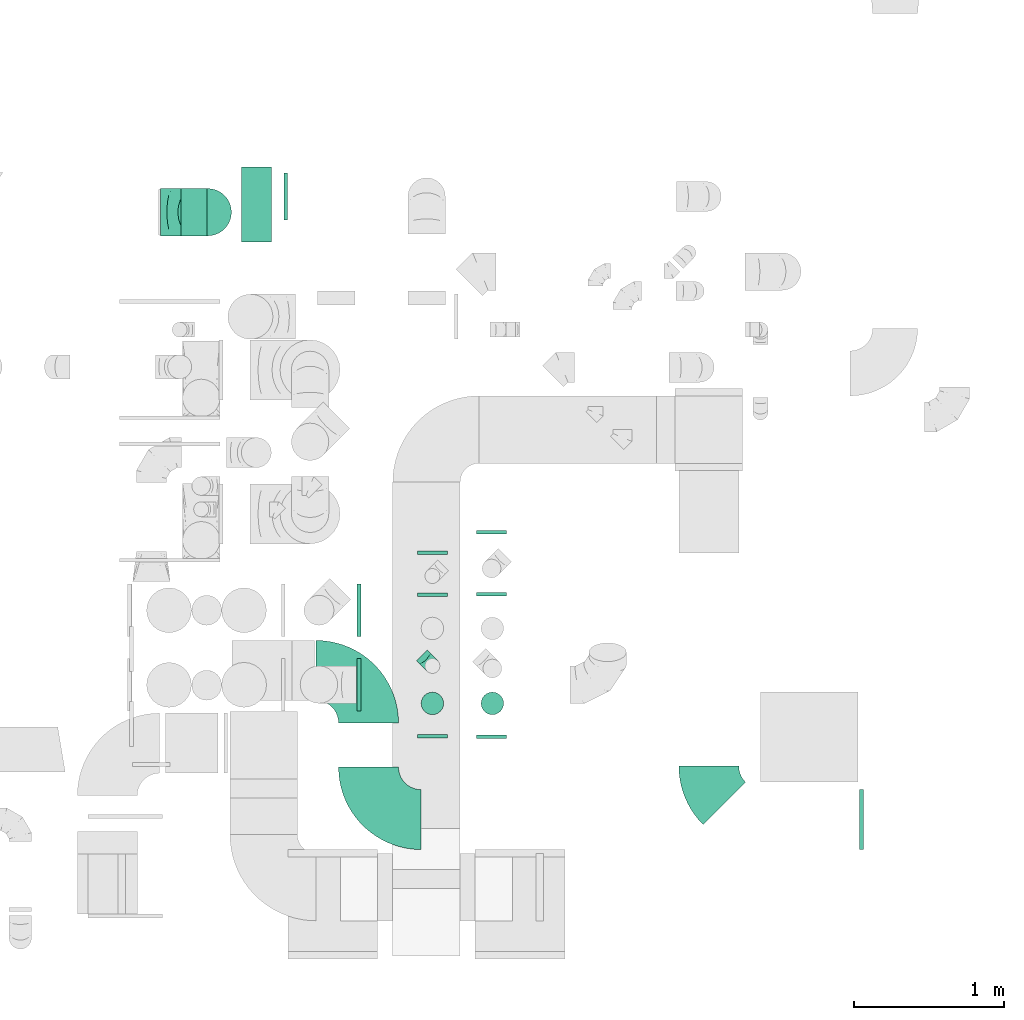
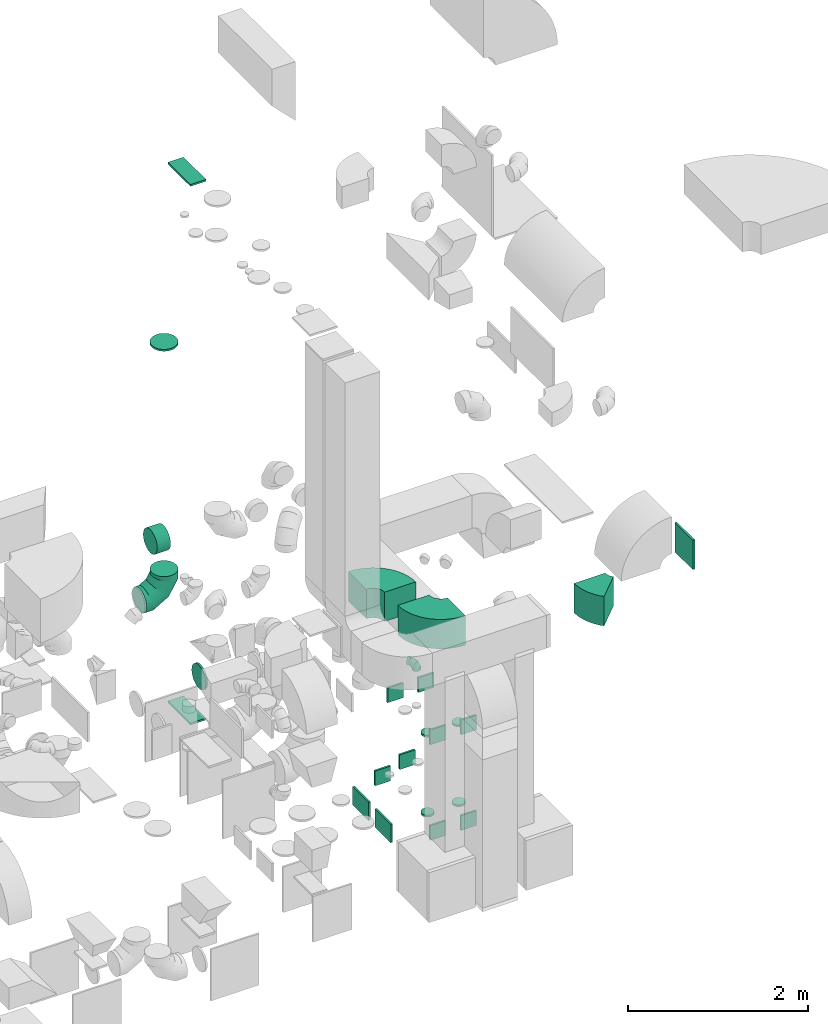
# One storey, part 35 of 59: 25 flow fittings.
"""IFC2X3 building model written with IfcOpenShell, lengths in millimetres."""

import ifcopenshell
import ifcopenshell.guid

model = None  # the IFC model being written
_history = None  # IfcOwnerHistory: only IFC2X3 demands one
_inside = {}  # id of a spatial element -> (the spatial element, [elements in it])
_under = {}  # id of a project, library or spatial element -> (it, [spatial elements below it])
_declared = {}  # id of a project -> (the project, [libraries it declares])
_typed = {}  # id of a type object -> (the type object, [elements of that type])
_made_of = {}  # id of a material, layer set ... -> (it, [elements and type objects made of it])


def new_model(schema):
    """Start an empty IFC model of exactly this schema.

    Asked for "IFC4X3", IfcOpenShell would pick the latest addendum, in which some entities
    have other attributes; the version numbers below select the first issue.
    IFC2X3 requires an IfcOwnerHistory on every rooted entity: one is made here for all.
    """
    global model, _history
    if schema == "IFC4X3":
        model = ifcopenshell.file(schema_version=(4, 3, 0, 0))
    else:
        model = ifcopenshell.file(schema=schema)
    _inside.clear()
    _under.clear()
    _declared.clear()
    _typed.clear()
    _made_of.clear()
    _history = None
    if model.schema == "IFC2X3":
        org = make("IfcOrganization", Name="unknown")
        user = make(
            "IfcPersonAndOrganization",
            ThePerson=make("IfcPerson", FamilyName="unknown"),
            TheOrganization=org,
        )
        app = make(
            "IfcApplication",
            ApplicationDeveloper=org,
            Version="unknown",
            ApplicationFullName="unknown",
            ApplicationIdentifier="unknown",
        )
        _history = make(
            "IfcOwnerHistory",
            OwningUser=user,
            OwningApplication=app,
            ChangeAction="ADDED",
            CreationDate=0,
        )
    return model


def make(cls, **values):
    """One entity of the class cls with the attributes given. An attribute that is None is left unset."""
    return model.create_entity(
        cls, **{name: value for name, value in values.items() if value is not None}
    )


def entity(cls, *values):
    """Any entity or typed value of the class cls, its attributes in the order of the schema. None: left unset."""
    e = model.create_entity(cls)
    for i, value in enumerate(values):
        if value is not None:
            e[i] = value
    return e


def rooted(cls, **values):
    """An entity with a GlobalId (a new one), such as an element, a storey or a relation."""
    return make(cls, GlobalId=ifcopenshell.guid.new(), OwnerHistory=_history, **values)


def si_unit(unit_type, name, prefix=None):
    """IfcSIUnit, for example si_unit("LENGTHUNIT", "METRE", prefix="MILLI")."""
    return make("IfcSIUnit", UnitType=unit_type, Prefix=prefix, Name=name)


def converted_unit(unit_type, name, factor, base, dimensions=None, offset=None):
    """IfcConversionBasedUnit, such as the inch: factor (a typed value) times the base unit."""
    return make(
        "IfcConversionBasedUnit"
        if offset is None
        else "IfcConversionBasedUnitWithOffset",
        ConversionOffset=offset,
        Dimensions=None
        if dimensions is None
        else entity("IfcDimensionalExponents", *dimensions),
        UnitType=unit_type,
        Name=name,
        ConversionFactor=make(
            "IfcMeasureWithUnit", ValueComponent=factor, UnitComponent=base
        ),
    )


def derived_unit(unit_type, elements):
    """IfcDerivedUnit: a product of units, each with its exponent."""
    return make(
        "IfcDerivedUnit",
        Elements=[
            make("IfcDerivedUnitElement", Unit=unit, Exponent=power)
            for unit, power in elements
        ],
        UnitType=unit_type,
    )


def assignment(units):
    """IfcUnitAssignment: the units of a project."""
    return None if units is None else make("IfcUnitAssignment", Units=units)


def point(xyz):
    """IfcCartesianPoint."""
    return None if xyz is None else make("IfcCartesianPoint", Coordinates=xyz)


def direction(xyz):
    """IfcDirection."""
    return None if xyz is None else make("IfcDirection", DirectionRatios=xyz)


def frame(location, z_axis=None, x_axis=None):
    """IfcAxis2Placement3D, a coordinate frame: its origin and axes. An axis left out is left unset."""
    return make(
        "IfcAxis2Placement3D",
        Location=point(location),
        Axis=direction(z_axis),
        RefDirection=direction(x_axis),
    )


def frame_2d(location, x_axis=None):
    """IfcAxis2Placement2D, a coordinate frame in the plane: its origin and x axis."""
    return make(
        "IfcAxis2Placement2D", Location=point(location), RefDirection=direction(x_axis)
    )


def origin():
    """The frame at (0, 0, 0) with its axes left unset."""
    return frame((0.0, 0.0, 0.0))


def origin_2d_with_axis():
    """The frame at (0, 0) in the plane with the x axis (1, 0) written out."""
    return frame_2d((0.0, 0.0), x_axis=(1.0, 0.0))


def place(relative_to, where):
    """IfcLocalPlacement: puts the frame where relative to a parent placement (None: the world)."""
    return make(
        "IfcLocalPlacement", PlacementRelTo=relative_to, RelativePlacement=where
    )


def context(
    kind, dimensions, precision=None, world=None, true_north=None, identifier=None
):
    """IfcGeometricRepresentationContext, for example the 3D "Model" context."""
    return make(
        "IfcGeometricRepresentationContext",
        ContextIdentifier=identifier,
        ContextType=kind,
        CoordinateSpaceDimension=dimensions,
        Precision=precision,
        WorldCoordinateSystem=world,
        TrueNorth=true_north,
    )


def subcontext(parent, identifier, kind, view, scale=None):
    """IfcGeometricRepresentationSubContext, for example "Body" below "Model"."""
    return make(
        "IfcGeometricRepresentationSubContext",
        ContextIdentifier=identifier,
        ContextType=kind,
        ParentContext=parent,
        TargetScale=scale,
        TargetView=view,
    )


def project(units=None, contexts=None):
    """IfcProject with its units and contexts."""
    return rooted(
        "IfcProject",
        Name="project",
        RepresentationContexts=contexts,
        UnitsInContext=assignment(units),
    )


def spatial(cls, under=None, at=None, **own):
    """A site, building, storey or space (cls), placed at a placement, below another one or the project."""
    s = rooted(cls, ObjectPlacement=at, **own)
    if under is not None:
        _under.setdefault(under.id(), (under, []))[1].append(s)
    return s


def polyline(points):
    """IfcPolyline through the points."""
    return make("IfcPolyline", Points=[point(p) for p in points])


def circle_curve(where, radius):
    """IfcCircle in the frame where."""
    return make("IfcCircle", Position=where, Radius=radius)


def parameter(value):
    """IfcParameterValue: where a trimmed curve begins or ends, as a parameter of its basis curve."""
    return model.create_entity("IfcParameterValue", value)


def trimmed(basis, trim1, trim2, sense, master):
    """IfcTrimmedCurve: the piece of a basis curve between two trims."""
    return make(
        "IfcTrimmedCurve",
        BasisCurve=basis,
        Trim1=trim1,
        Trim2=trim2,
        SenseAgreement=sense,
        MasterRepresentation=master,
    )


def segment(curve, same_sense, transition):
    """IfcCompositeCurveSegment."""
    return make(
        "IfcCompositeCurveSegment",
        Transition=transition,
        SameSense=same_sense,
        ParentCurve=curve,
    )


def composite_curve(segments, self_intersect=None):
    """IfcCompositeCurve: segments joined end to end."""
    return make("IfcCompositeCurve", Segments=segments, SelfIntersect=self_intersect)


def profile(cls, at=None, kind="AREA", **sizes):
    """A parametric profile (cls). Its sizes go by their IFC names, for example OverallWidth=200.0."""
    return make(cls, ProfileType=kind, Position=at, **sizes)


def rectangle(**sizes):
    """IfcRectangleProfileDef."""
    return profile("IfcRectangleProfileDef", **sizes)


def circle(**sizes):
    """IfcCircleProfileDef."""
    return profile("IfcCircleProfileDef", **sizes)


def outline(outer, holes=None, kind="AREA"):
    """IfcArbitraryClosedProfileDef: a profile drawn as a closed curve; with holes, ...WithVoids."""
    if holes is None:
        return make("IfcArbitraryClosedProfileDef", ProfileType=kind, OuterCurve=outer)
    return make(
        "IfcArbitraryProfileDefWithVoids",
        ProfileType=kind,
        OuterCurve=outer,
        InnerCurves=holes,
    )


def extrude(swept, where, along, depth):
    """IfcExtrudedAreaSolid: the profile swept, set in the frame where, extruded along a direction by depth."""
    return make(
        "IfcExtrudedAreaSolid",
        SweptArea=swept,
        Position=where,
        ExtrudedDirection=direction(along),
        Depth=depth,
    )


def faces_of(points, faces, orient=None, outer=None):
    """IfcFace entities. A face is a list of loops; a loop is a list of indices into points, from 0.

    orient and outer hold one flag for each loop. By default every Orientation is true, the
    first loop of a face is its IfcFaceOuterBound and the others are IfcFaceBound.
    """
    made = []
    for i, loops in enumerate(faces):
        bounds = []
        for j, loop in enumerate(loops):
            is_outer = j == 0 if outer is None else outer[i][j]
            bounds.append(
                make(
                    "IfcFaceOuterBound" if is_outer else "IfcFaceBound",
                    Bound=make("IfcPolyLoop", Polygon=[points[k] for k in loop]),
                    Orientation=True if orient is None else orient[i][j],
                )
            )
        made.append(make("IfcFace", Bounds=bounds))
    return made


def faceted_brep(points, faces, orient=None, outer=None, voids=None):
    """IfcFacetedBrep: a solid bounded by flat faces; with voids (closed shells), ...WithVoids."""
    shared = [point(p) for p in points]
    hull = make("IfcClosedShell", CfsFaces=faces_of(shared, faces, orient, outer))
    if voids is None:
        return make("IfcFacetedBrep", Outer=hull)
    return make(
        "IfcFacetedBrepWithVoids",
        Outer=hull,
        Voids=[
            make(cls, CfsFaces=faces_of(shared, fs, o, b)) for cls, fs, o, b in voids
        ],
    )


def shape(context_of_items, identifier, shape_type, items):
    """IfcShapeRepresentation: the items that make up one representation, for example the "Body"."""
    return make(
        "IfcShapeRepresentation",
        ContextOfItems=context_of_items,
        RepresentationIdentifier=identifier,
        RepresentationType=shape_type,
        Items=items,
    )


def source(mapping_origin, context_of_items, identifier, shape_type, items):
    """IfcRepresentationMap: a shape defined once, which mapped items show again and again."""
    return make(
        "IfcRepresentationMap",
        MappingOrigin=mapping_origin,
        MappedRepresentation=shape(context_of_items, identifier, shape_type, items),
    )


def transform(
    local_origin,
    x_axis=None,
    y_axis=None,
    z_axis=None,
    scale=None,
    scale2=None,
    scale3=None,
    uniform=True,
):
    """IfcCartesianTransformationOperator3D, or its non-uniform kind. x_axis, y_axis, z_axis: its Axis1, 2, 3."""
    if uniform:
        return make(
            "IfcCartesianTransformationOperator3D",
            Axis1=direction(x_axis),
            Axis2=direction(y_axis),
            LocalOrigin=point(local_origin),
            Scale=scale,
            Axis3=direction(z_axis),
        )
    return make(
        "IfcCartesianTransformationOperator3DnonUniform",
        Axis1=direction(x_axis),
        Axis2=direction(y_axis),
        LocalOrigin=point(local_origin),
        Scale=scale,
        Axis3=direction(z_axis),
        Scale2=scale2,
        Scale3=scale3,
    )


def mapped(mapping_source, mapping_target):
    """IfcMappedItem: shows the shape of a source again, moved by a transform."""
    return make(
        "IfcMappedItem", MappingSource=mapping_source, MappingTarget=mapping_target
    )


def material(Name=None, Category=None):
    """IfcMaterial."""
    return make("IfcMaterial", Name=Name, Category=Category)


def made_of(thing, what):
    """Note that an element or type object is made of a material, layer set ...; save() writes the relation."""
    if what is not None:
        _made_of.setdefault(what.id(), (what, []))[1].append(thing)
    return thing


def type_object(cls, material=None, **own):
    """A type object (cls), such as IfcWallType, which elements share."""
    return made_of(rooted(cls, **own), material)


def type_shapes(of_type, sources):
    """Give a type object the sources (RepresentationMaps) that its elements show as mapped items."""
    of_type.RepresentationMaps = sources


def element(
    cls,
    number,
    at=None,
    inside=None,
    cuts=None,
    type_object=None,
    material=None,
    context=None,
    identifier="Body",
    shape_type=None,
    held_by="IfcProductDefinitionShape",
    body=None,
    shapes=None,
    **own,
):
    """One element of the class cls, such as IfcWall. Its Tag is "e" and its number.

    at: its placement. inside: the storey or other place that contains it. cuts: it is an
    opening in that element (IfcRelVoidsElement). A single representation is given by context,
    identifier, shape_type and body (its items); several are given by shapes. held_by: the class
    of the entity that holds the representations. save() writes the other relations.
    """
    e = rooted(cls, Tag="e%d" % number, ObjectPlacement=at, **own)
    if body is not None:
        shapes = [shape(context, identifier, shape_type, body)]
    if shapes is not None:
        e.Representation = make(held_by, Representations=shapes)
    if inside is not None:
        _inside.setdefault(inside.id(), (inside, []))[1].append(e)
    if cuts is not None:
        rooted(
            "IfcRelVoidsElement", RelatingBuildingElement=cuts, RelatedOpeningElement=e
        )
    if type_object is not None:
        _typed.setdefault(type_object.id(), (type_object, []))[1].append(e)
    return made_of(e, material)


def aggregate(whole, parts):
    """IfcRelAggregates: a whole, such as a stair, and the parts it consists of."""
    return rooted("IfcRelAggregates", RelatingObject=whole, RelatedObjects=parts)


def save(model, path):
    """Write the relations noted so far, then the file.

    IfcRelAggregates (storeys below a building ...), IfcRelContainedInSpatialStructure (elements
    in a storey), IfcRelDefinesByType, IfcRelAssociatesMaterial and IfcRelDeclares: one each for
    every whole, place, type object, material and project.
    """
    for whole, parts in _under.values():
        aggregate(whole, parts)
    for where, things in _inside.values():
        rooted(
            "IfcRelContainedInSpatialStructure",
            RelatedElements=things,
            RelatingStructure=where,
        )
    for kind, things in _typed.values():
        rooted("IfcRelDefinesByType", RelatedObjects=things, RelatingType=kind)
    for what, things in _made_of.values():
        rooted("IfcRelAssociatesMaterial", RelatedObjects=things, RelatingMaterial=what)
    for by, libraries in _declared.values():
        rooted("IfcRelDeclares", RelatingContext=by, RelatedDefinitions=libraries)
    model.write(path)


model = new_model("IFC2X3")

# Units and contexts
model_context = context("Model", 3, precision=0.01, world=origin(), true_north=direction((6.12303176911189e-17, 1.0)))
body_context = subcontext(model_context, "Body", "Model", "MODEL_VIEW")
ifc_project = project(units=[si_unit("LENGTHUNIT", "METRE", prefix="MILLI"), si_unit("AREAUNIT", "SQUARE_METRE"), si_unit("VOLUMEUNIT", "CUBIC_METRE"), converted_unit("PLANEANGLEUNIT", "DEGREE", entity("IfcRatioMeasure", 0.0174532925199433), si_unit("PLANEANGLEUNIT", "RADIAN"), dimensions=[0, 0, 0, 0, 0, 0, 0]), si_unit("MASSUNIT", "GRAM", prefix="KILO"), derived_unit("MASSDENSITYUNIT", [(si_unit("MASSUNIT", "GRAM", prefix="KILO"), 1), (si_unit("LENGTHUNIT", "METRE"), -3)]), derived_unit("MOMENTOFINERTIAUNIT", [(si_unit("LENGTHUNIT", "METRE"), 4)]), si_unit("TIMEUNIT", "SECOND"), si_unit("FREQUENCYUNIT", "HERTZ"), si_unit("THERMODYNAMICTEMPERATUREUNIT", "DEGREE_CELSIUS"), derived_unit("THERMALTRANSMITTANCEUNIT", [(si_unit("MASSUNIT", "GRAM", prefix="KILO"), 1), (si_unit("THERMODYNAMICTEMPERATUREUNIT", "KELVIN"), -1), (si_unit("TIMEUNIT", "SECOND"), -3)]), derived_unit("VOLUMETRICFLOWRATEUNIT", [(si_unit("LENGTHUNIT", "METRE"), 3), (si_unit("TIMEUNIT", "SECOND"), -1)]), derived_unit("MASSFLOWRATEUNIT", [(si_unit("MASSUNIT", "GRAM", prefix="KILO"), 1), (si_unit("TIMEUNIT", "SECOND"), -1)]), derived_unit("ROTATIONALFREQUENCYUNIT", [(si_unit("TIMEUNIT", "SECOND"), -1)]), si_unit("ELECTRICCURRENTUNIT", "AMPERE"), si_unit("ELECTRICVOLTAGEUNIT", "VOLT"), si_unit("POWERUNIT", "WATT"), si_unit("FORCEUNIT", "NEWTON", prefix="KILO"), si_unit("ILLUMINANCEUNIT", "LUX"), si_unit("LUMINOUSFLUXUNIT", "LUMEN"), si_unit("LUMINOUSINTENSITYUNIT", "CANDELA"), derived_unit("USERDEFINED", [(si_unit("MASSUNIT", "GRAM", prefix="KILO"), -1), (si_unit("LENGTHUNIT", "METRE"), -2), (si_unit("TIMEUNIT", "SECOND"), 3), (si_unit("LUMINOUSFLUXUNIT", "LUMEN"), 1)]), derived_unit("LINEARVELOCITYUNIT", [(si_unit("LENGTHUNIT", "METRE"), 1), (si_unit("TIMEUNIT", "SECOND"), -1)]), si_unit("PRESSUREUNIT", "PASCAL"), derived_unit("USERDEFINED", [(si_unit("LENGTHUNIT", "METRE"), -2), (si_unit("MASSUNIT", "GRAM", prefix="KILO"), 1), (si_unit("TIMEUNIT", "SECOND"), -2)]), derived_unit("LINEARFORCEUNIT", [(si_unit("MASSUNIT", "GRAM", prefix="KILO"), 1), (si_unit("LENGTHUNIT", "METRE"), 1), (si_unit("TIMEUNIT", "SECOND"), -2), (si_unit("LENGTHUNIT", "METRE"), -1)]), derived_unit("PLANARFORCEUNIT", [(si_unit("MASSUNIT", "GRAM", prefix="KILO"), 1), (si_unit("LENGTHUNIT", "METRE"), 1), (si_unit("TIMEUNIT", "SECOND"), -2), (si_unit("LENGTHUNIT", "METRE"), -2)])], contexts=[model_context])

# Site, building, storey
site_placement = place(None, origin())
site = spatial("IfcSite", under=ifc_project, at=site_placement, CompositionType="ELEMENT")
building_placement = place(site_placement, origin())
building = spatial("IfcBuilding", under=site, at=building_placement, CompositionType="ELEMENT")
storey_placement = place(building_placement, frame((0.0, 0.0, 28200.0)))
storey = spatial("IfcBuildingStorey", under=building, at=storey_placement, CompositionType="ELEMENT", Elevation=28200.0)

# Flow fittings
ifc_material = material()
duct_fitting_type_1 = type_object("IfcDuctFittingType", PredefinedType="NOTDEFINED", material=ifc_material)
shared_shape_1 = source(origin(), body_context, "Body", "SweptSolid", [
    extrude(rectangle(XDim=24.9999999999999, YDim=400.0, at=origin_2d_with_axis()), frame((12.5, 0.0, -200.0)), (0.0, 0.0, 1.0), 400.0),
])
type_shapes(duct_fitting_type_1, [shared_shape_1])
flow_fitting_1_placement = place(storey_placement, frame((59986.38, 8838.29, 3500.0)))
element("IfcFlowFitting", 1, at=flow_fitting_1_placement, inside=storey, type_object=duct_fitting_type_1, material=ifc_material, context=body_context, shape_type="MappedRepresentation", body=[
    mapped(shared_shape_1, transform((0.0, 0.0, 0.0), scale=1.0)),
])
duct_fitting_type_2 = type_object("IfcDuctFittingType", PredefinedType="NOTDEFINED", material=ifc_material)
shared_shape_2 = source(origin(), body_context, "Body", "SweptSolid", [
    extrude(rectangle(XDim=24.9999999999999, YDim=200.0, at=origin_2d_with_axis()), frame((12.5, 0.0, -100.0)), (0.0, 0.0, 1.0), 200.0),
])
type_shapes(duct_fitting_type_2, [shared_shape_2])
for number, where, z_axis, x_axis in (
    (2, (57136.5, 10605.81, 300.0), (0.0, 0.0, 1.0), (0.0, 1.0, 0.0)),
    (3, (57136.5, 9405.81, 1600.0), (0.0, 0.0, 1.0), (0.0, -1.0, 0.0)),
    (4, (57136.5, 10325.81, 1600.0), (0.0, 0.0, 1.0), (0.0, 1.0, 0.0)),
    (5, (57531.19, 10742.81, 300.0), (0.0, 0.0, 1.0), (0.0, 1.0, 0.0)),
    (6, (57531.19, 10327.81, 1600.0), (0.0, 0.0, 1.0), (0.0, 1.0, 0.0)),
    (7, (57531.19, 9402.81, 1600.0), (0.0, 0.0, 1.0), (0.0, -1.0, 0.0)),
    (8, (57531.19, 9402.81, 300.0), (0.0, 0.0, 1.0), (0.0, -1.0, 0.0)),
    (9, (57136.5, 9405.81, 300.0), (0.0, 0.0, 1.0), (0.0, -1.0, 0.0)),
):
    element("IfcFlowFitting", number, at=place(storey_placement, frame(where, z_axis=z_axis, x_axis=x_axis)), inside=storey, type_object=duct_fitting_type_2, material=ifc_material, context=body_context, shape_type="MappedRepresentation", body=[
        mapped(shared_shape_2, transform((0.0, 0.0, 0.0), scale=1.0)),
    ])
duct_fitting_type_3 = type_object("IfcDuctFittingType", PredefinedType="NOTDEFINED", material=ifc_material)
shared_shape_3 = source(origin(), body_context, "Body", "SweptSolid", [
    extrude(circle(Radius=157.499999999999, at=origin_2d_with_axis()), frame((0.0, 0.0, 0.0), z_axis=(1.0, 0.0, 0.0), x_axis=(0.0, 1.0, 0.0)), (0.0, 0.0, 1.0), 25.0000000000018),
])
type_shapes(duct_fitting_type_3, [shared_shape_3])
for number, where, z_axis, x_axis in (
    (10, (56170.78, 12994.01, 550.0), (0.0, 0.0, 1.0), (-1.0, 0.0, 0.0)),
    (11, (55638.51, 12889.46, 5325.51), (-1.0, 0.0, 0.0), (0.0, 0.0, 1.0)),
):
    element("IfcFlowFitting", number, at=place(storey_placement, frame(where, z_axis=z_axis, x_axis=x_axis)), inside=storey, type_object=duct_fitting_type_3, material=ifc_material, context=body_context, shape_type="MappedRepresentation", body=[
        mapped(shared_shape_3, transform((0.0, 0.0, 0.0), scale=1.0)),
    ])
duct_fitting_type_4 = type_object("IfcDuctFittingType", PredefinedType="NOTDEFINED", material=ifc_material)
shared_shape_4 = source(origin(), body_context, "Body", "SweptSolid", [
    extrude(rectangle(XDim=24.9999999999999, YDim=350.0, at=origin_2d_with_axis()), frame((12.5, 0.0, -125.0)), (0.0, 0.0, 1.0), 250.0),
])
type_shapes(duct_fitting_type_4, [shared_shape_4])
for number, where in (
    (12, (56633.85, 9736.5, 325.0)),
    (13, (56633.85, 10234.06, 325.0)),
):
    element("IfcFlowFitting", number, at=place(storey_placement, frame(where)), inside=storey, type_object=duct_fitting_type_4, material=ifc_material, context=body_context, shape_type="MappedRepresentation", body=[
        mapped(shared_shape_4, transform((0.0, 0.0, 0.0), scale=1.0)),
    ])
duct_fitting_type_5 = type_object("IfcDuctFittingType", PredefinedType="NOTDEFINED", material=ifc_material)
shared_shape_5 = source(origin(), body_context, "Body", "SweptSolid", [
    extrude(rectangle(XDim=24.9999999999999, YDim=500.0, at=origin_2d_with_axis()), frame((12.5, 0.0, -100.0)), (0.0, 0.0, 1.0), 200.0),
])
type_shapes(duct_fitting_type_5, [shared_shape_5])
for number, where, z_axis, x_axis in (
    (14, (55963.0, 12939.46, 200.0), (-1.0, 0.0, 0.0), (0.0, 0.0, -1.0)),
    (15, (55963.0, 12939.46, 7500.23), (-1.0, 0.0, 0.0), (0.0, 0.0, 1.0)),
):
    element("IfcFlowFitting", number, at=place(storey_placement, frame(where, z_axis=z_axis, x_axis=x_axis)), inside=storey, type_object=duct_fitting_type_5, material=ifc_material, context=body_context, shape_type="MappedRepresentation", body=[
        mapped(shared_shape_5, transform((0.0, 0.0, 0.0), scale=1.0)),
    ])
duct_fitting_type_6 = type_object("IfcDuctFittingType", PredefinedType="NOTDEFINED", material=ifc_material)
shared_shape_6 = source(origin(), body_context, "Body", "Brep", [
    faceted_brep([(-100.0, 0.0, -50.0), (-100.0, -12.94, -48.3), (-100.0, -25.0, -43.3), (-100.0, -35.36, -35.36), (-100.0, -43.3, -25.0), (-100.0, -48.3, -12.94), (-100.0, -50.0, 0.0), (-100.0, -48.3, 12.94), (-100.0, -43.3, 25.0), (-100.0, -35.36, 35.36), (-100.0, -25.0, 43.3), (-100.0, -12.94, 48.3), (-100.0, 0.0, 50.0), (-100.0, 12.94, 48.3), (-100.0, 25.0, 43.3), (-100.0, 35.36, 35.36), (-100.0, 43.3, 25.0), (-100.0, 48.3, 12.94), (-100.0, 50.0, 0.0), (-100.0, 48.3, -12.94), (-100.0, 43.3, -25.0), (-100.0, 35.36, -35.36), (-100.0, 25.0, -43.3), (-100.0, 12.94, -48.3), (-76.67, 12.94, 48.3), (-79.9, 25.0, 43.3), (-73.21, 0.0, 50.0), (-82.68, 35.36, 35.36), (-86.15, 48.3, 12.94), (-86.6, 50.0, 0.0), (-84.81, 43.3, 25.0), (-84.81, 43.3, -25.0), (-82.68, 35.36, -35.36), (-86.15, 48.3, -12.94), (-76.67, 12.94, -48.3), (-73.21, 0.0, -50.0), (-79.9, 25.0, -43.3), (-69.74, -12.94, -48.3), (-66.51, -25.0, -43.3), (-63.73, -35.36, -35.36), (-61.6, -43.3, -25.0), (-60.26, -48.3, -12.94), (-59.81, -50.0, 0.0), (-60.26, -48.3, 12.94), (-61.6, -43.3, 25.0), (-63.73, -35.36, 35.36), (-66.51, -25.0, 43.3), (-69.74, -12.94, 48.3), (-36.27, 36.27, 48.3), (-45.1, 45.1, 43.3), (-26.79, 26.79, 50.0), (-52.68, 52.68, 35.36), (-58.49, 58.49, 25.0), (-62.15, 62.15, 12.94), (-63.4, 63.4, 0.0), (-62.15, 62.15, -12.94), (-58.49, 58.49, -25.0), (-52.68, 52.68, -35.36), (-36.27, 36.27, -48.3), (-26.79, 26.79, -50.0), (-45.1, 45.1, -43.3), (-17.32, 17.32, -48.3), (-8.49, 8.49, -43.3), (-0.91, 0.91, -35.36), (4.9, -4.9, -25.0), (8.56, -8.56, -12.94), (9.81, -9.81, 0.0), (8.56, -8.56, 12.94), (4.9, -4.9, 25.0), (-0.91, 0.91, 35.36), (-8.49, 8.49, 43.3), (-17.32, 17.32, 48.3), (-12.94, 76.67, 48.3), (-25.0, 79.9, 43.3), (0.0, 73.21, 50.0), (-35.36, 82.68, 35.36), (-43.3, 84.81, 25.0), (-48.3, 86.15, 12.94), (-50.0, 86.6, 0.0), (-48.3, 86.15, -12.94), (-43.3, 84.81, -25.0), (-35.36, 82.68, -35.36), (-12.94, 76.67, -48.3), (0.0, 73.21, -50.0), (-25.0, 79.9, -43.3), (12.94, 69.74, -48.3), (25.0, 66.51, -43.3), (35.36, 63.73, -35.36), (43.3, 61.6, -25.0), (48.3, 60.26, -12.94), (50.0, 59.81, 0.0), (48.3, 60.26, 12.94), (43.3, 61.6, 25.0), (35.36, 63.73, 35.36), (25.0, 66.51, 43.3), (12.94, 69.74, 48.3), (-12.94, 100.0, -48.3), (-25.0, 100.0, -43.3), (-35.36, 100.0, -35.36), (-43.3, 100.0, -25.0), (-48.3, 100.0, -12.94), (-50.0, 100.0, 0.0), (-48.3, 100.0, 12.94), (-43.3, 100.0, 25.0), (-35.36, 100.0, 35.36), (-25.0, 100.0, 43.3), (-12.94, 100.0, 48.3), (0.0, 100.0, 50.0), (12.94, 100.0, 48.3), (25.0, 100.0, 43.3), (35.36, 100.0, 35.36), (43.3, 100.0, 25.0), (48.3, 100.0, 12.94), (50.0, 100.0, 0.0), (48.3, 100.0, -12.94), (43.3, 100.0, -25.0), (35.36, 100.0, -35.36), (25.0, 100.0, -43.3), (12.94, 100.0, -48.3), (0.0, 100.0, -50.0)], [[[0, 1, 2, 3, 4, 5, 6, 7, 8, 9, 10, 11, 12, 13, 14, 15, 16, 17, 18, 19, 20, 21, 22, 23]], [[24, 25, 14, 13]], [[26, 24, 13, 12]], [[14, 25, 27, 15]], [[28, 29, 18, 17]], [[30, 28, 17, 16]], [[15, 27, 30, 16]], [[20, 31, 32, 21]], [[33, 31, 20, 19]], [[18, 29, 33, 19]], [[34, 35, 0, 23]], [[36, 34, 23, 22]], [[32, 36, 22, 21]], [[2, 1, 37, 38]], [[3, 2, 38, 39]], [[0, 35, 37, 1]], [[5, 4, 40, 41]], [[6, 5, 41, 42]], [[3, 39, 40, 4]], [[6, 42, 43, 7]], [[7, 43, 44, 8]], [[8, 44, 45, 9]], [[10, 46, 47, 11]], [[11, 47, 26, 12]], [[10, 9, 45, 46]], [[48, 49, 25, 24]], [[50, 48, 24, 26]], [[27, 25, 49, 51]], [[52, 53, 28, 30]], [[51, 52, 30, 27]], [[29, 28, 53, 54]], [[55, 56, 31, 33]], [[54, 55, 33, 29]], [[57, 32, 31, 56]], [[58, 59, 35, 34]], [[60, 58, 34, 36]], [[57, 60, 36, 32]], [[37, 35, 59, 61]], [[38, 37, 61, 62]], [[39, 38, 62, 63]], [[41, 40, 64, 65]], [[42, 41, 65, 66]], [[63, 64, 40, 39]], [[43, 42, 66, 67]], [[44, 43, 67, 68]], [[68, 69, 45, 44]], [[46, 45, 69, 70]], [[47, 46, 70, 71]], [[26, 47, 71, 50]], [[72, 73, 49, 48]], [[74, 72, 48, 50]], [[51, 49, 73, 75]], [[76, 77, 53, 52]], [[75, 76, 52, 51]], [[54, 53, 77, 78]], [[79, 80, 56, 55]], [[78, 79, 55, 54]], [[81, 57, 56, 80]], [[82, 83, 59, 58]], [[84, 82, 58, 60]], [[81, 84, 60, 57]], [[61, 59, 83, 85]], [[62, 61, 85, 86]], [[63, 62, 86, 87]], [[65, 64, 88, 89]], [[66, 65, 89, 90]], [[87, 88, 64, 63]], [[67, 66, 90, 91]], [[68, 67, 91, 92]], [[92, 93, 69, 68]], [[70, 69, 93, 94]], [[71, 70, 94, 95]], [[50, 71, 95, 74]], [[96, 97, 98, 99, 100, 101, 102, 103, 104, 105, 106, 107, 108, 109, 110, 111, 112, 113, 114, 115, 116, 117, 118, 119]], [[72, 74, 107, 106]], [[73, 72, 106, 105]], [[75, 73, 105, 104]], [[77, 76, 103, 102]], [[78, 77, 102, 101]], [[75, 104, 103, 76]], [[78, 101, 100, 79]], [[79, 100, 99, 80]], [[80, 99, 98, 81]], [[96, 119, 83, 82]], [[97, 96, 82, 84]], [[84, 81, 98, 97]], [[83, 119, 118, 85]], [[85, 118, 117, 86]], [[86, 117, 116, 87]], [[88, 115, 114, 89]], [[89, 114, 113, 90]], [[87, 116, 115, 88]], [[91, 90, 113, 112]], [[92, 91, 112, 111]], [[93, 92, 111, 110]], [[95, 94, 109, 108]], [[74, 95, 108, 107]], [[110, 109, 94, 93]]]),
])
type_shapes(duct_fitting_type_6, [shared_shape_6])
flow_fitting_2_placement = place(storey_placement, frame((57136.5, 9862.81, 2305.0), z_axis=(0.707106781186552, 0.707106781186543, 0.0), x_axis=(0.707106781186543, -0.707106781186552, 0.0)))
element("IfcFlowFitting", 16, at=flow_fitting_2_placement, inside=storey, type_object=duct_fitting_type_6, material=ifc_material, context=body_context, shape_type="MappedRepresentation", body=[
    mapped(shared_shape_6, transform((0.0, 0.0, 0.0), scale=1.0)),
])
duct_fitting_type_7 = type_object("IfcDuctFittingType", PredefinedType="NOTDEFINED", material=ifc_material)
shared_shape_7 = source(origin(), body_context, "Body", "Brep", [
    faceted_brep([(-315.0, 0.0, -157.5), (-315.0, -40.76, -152.13), (-315.0, -78.75, -136.4), (-315.0, -111.37, -111.37), (-315.0, -136.4, -78.75), (-315.0, -152.13, -40.76), (-315.0, -157.5, 0.0), (-315.0, -152.13, 40.76), (-315.0, -136.4, 78.75), (-315.0, -111.37, 111.37), (-315.0, -78.75, 136.4), (-315.0, -40.76, 152.13), (-315.0, 0.0, 157.5), (-315.0, 40.76, 152.13), (-315.0, 78.75, 136.4), (-315.0, 111.37, 111.37), (-315.0, 136.4, 78.75), (-315.0, 152.13, 40.76), (-315.0, 157.5, 0.0), (-315.0, 152.13, -40.76), (-315.0, 136.4, -78.75), (-315.0, 111.37, -111.37), (-315.0, 78.75, -136.4), (-315.0, 40.76, -152.13), (-241.52, 40.76, 152.13), (-251.7, 78.75, 136.4), (-230.6, 0.0, 157.5), (-260.44, 111.37, 111.37), (-271.36, 152.13, 40.76), (-272.8, 157.5, 0.0), (-267.14, 136.4, 78.75), (-267.14, 136.4, -78.75), (-260.44, 111.37, -111.37), (-271.36, 152.13, -40.76), (-241.52, 40.76, -152.13), (-230.6, 0.0, -157.5), (-251.7, 78.75, -136.4), (-219.67, -40.76, -152.13), (-209.5, -78.75, -136.4), (-200.75, -111.37, -111.37), (-194.05, -136.4, -78.75), (-189.83, -152.13, -40.76), (-188.39, -157.5, 0.0), (-189.83, -152.13, 40.76), (-194.05, -136.4, 78.75), (-200.75, -111.37, 111.37), (-209.5, -78.75, 136.4), (-219.67, -40.76, 152.13), (-114.25, 114.25, 152.13), (-142.05, 142.05, 136.4), (-84.4, 84.4, 157.5), (-165.93, 165.93, 111.37), (-184.25, 184.25, 78.75), (-195.77, 195.77, 40.76), (-199.7, 199.7, 0.0), (-195.77, 195.77, -40.76), (-184.25, 184.25, -78.75), (-165.93, 165.93, -111.37), (-114.25, 114.25, -152.13), (-84.4, 84.4, -157.5), (-142.05, 142.05, -136.4), (-54.56, 54.56, -152.13), (-26.75, 26.75, -136.4), (-2.88, 2.88, -111.37), (15.45, -15.45, -78.75), (26.97, -26.97, -40.76), (30.89, -30.89, 0.0), (26.97, -26.97, 40.76), (15.45, -15.45, 78.75), (-2.88, 2.88, 111.37), (-26.75, 26.75, 136.4), (-54.56, 54.56, 152.13), (-40.76, 241.52, 152.13), (-78.75, 251.7, 136.4), (0.0, 230.6, 157.5), (-111.37, 260.44, 111.37), (-136.4, 267.14, 78.75), (-152.13, 271.36, 40.76), (-157.5, 272.8, 0.0), (-152.13, 271.36, -40.76), (-136.4, 267.14, -78.75), (-111.37, 260.44, -111.37), (-40.76, 241.52, -152.13), (0.0, 230.6, -157.5), (-78.75, 251.7, -136.4), (40.76, 219.67, -152.13), (78.75, 209.5, -136.4), (111.37, 200.75, -111.37), (136.4, 194.05, -78.75), (152.13, 189.83, -40.76), (157.5, 188.39, 0.0), (152.13, 189.83, 40.76), (136.4, 194.05, 78.75), (111.37, 200.75, 111.37), (78.75, 209.5, 136.4), (40.76, 219.67, 152.13), (-40.76, 315.0, -152.13), (-78.75, 315.0, -136.4), (-111.37, 315.0, -111.37), (-136.4, 315.0, -78.75), (-152.13, 315.0, -40.76), (-157.5, 315.0, 0.0), (-152.13, 315.0, 40.76), (-136.4, 315.0, 78.75), (-111.37, 315.0, 111.37), (-78.75, 315.0, 136.4), (-40.76, 315.0, 152.13), (0.0, 315.0, 157.5), (40.76, 315.0, 152.13), (78.75, 315.0, 136.4), (111.37, 315.0, 111.37), (136.4, 315.0, 78.75), (152.13, 315.0, 40.76), (157.5, 315.0, 0.0), (152.13, 315.0, -40.76), (136.4, 315.0, -78.75), (111.37, 315.0, -111.37), (78.75, 315.0, -136.4), (40.76, 315.0, -152.13), (0.0, 315.0, -157.5)], [[[0, 1, 2, 3, 4, 5, 6, 7, 8, 9, 10, 11, 12, 13, 14, 15, 16, 17, 18, 19, 20, 21, 22, 23]], [[24, 25, 14, 13]], [[26, 24, 13, 12]], [[14, 25, 27, 15]], [[28, 29, 18, 17]], [[30, 28, 17, 16]], [[15, 27, 30, 16]], [[20, 31, 32, 21]], [[33, 31, 20, 19]], [[18, 29, 33, 19]], [[34, 35, 0, 23]], [[36, 34, 23, 22]], [[32, 36, 22, 21]], [[1, 0, 35, 37]], [[2, 1, 37, 38]], [[38, 39, 3, 2]], [[5, 4, 40, 41]], [[6, 5, 41, 42]], [[39, 40, 4, 3]], [[6, 42, 43, 7]], [[7, 43, 44, 8]], [[8, 44, 45, 9]], [[9, 45, 46, 10]], [[10, 46, 47, 11]], [[26, 12, 11, 47]], [[48, 49, 25, 24]], [[50, 48, 24, 26]], [[27, 25, 49, 51]], [[52, 53, 28, 30]], [[51, 52, 30, 27]], [[29, 28, 53, 54]], [[55, 56, 31, 33]], [[54, 55, 33, 29]], [[32, 31, 56, 57]], [[58, 59, 35, 34]], [[60, 58, 34, 36]], [[57, 60, 36, 32]], [[37, 35, 59, 61]], [[38, 37, 61, 62]], [[39, 38, 62, 63]], [[41, 40, 64, 65]], [[42, 41, 65, 66]], [[63, 64, 40, 39]], [[43, 42, 66, 67]], [[44, 43, 67, 68]], [[68, 69, 45, 44]], [[46, 45, 69, 70]], [[47, 46, 70, 71]], [[26, 47, 71, 50]], [[72, 73, 49, 48]], [[74, 72, 48, 50]], [[51, 49, 73, 75]], [[76, 77, 53, 52]], [[75, 76, 52, 51]], [[54, 53, 77, 78]], [[79, 80, 56, 55]], [[78, 79, 55, 54]], [[57, 56, 80, 81]], [[82, 83, 59, 58]], [[84, 82, 58, 60]], [[81, 84, 60, 57]], [[61, 59, 83, 85]], [[62, 61, 85, 86]], [[63, 62, 86, 87]], [[65, 64, 88, 89]], [[66, 65, 89, 90]], [[87, 88, 64, 63]], [[67, 66, 90, 91]], [[68, 67, 91, 92]], [[92, 93, 69, 68]], [[70, 69, 93, 94]], [[71, 70, 94, 95]], [[50, 71, 95, 74]], [[96, 97, 98, 99, 100, 101, 102, 103, 104, 105, 106, 107, 108, 109, 110, 111, 112, 113, 114, 115, 116, 117, 118, 119]], [[106, 105, 73, 72]], [[107, 106, 72, 74]], [[75, 73, 105, 104]], [[77, 76, 103, 102]], [[78, 77, 102, 101]], [[104, 103, 76, 75]], [[78, 101, 100, 79]], [[79, 100, 99, 80]], [[98, 81, 80, 99]], [[84, 97, 96, 82]], [[82, 96, 119, 83]], [[97, 84, 81, 98]], [[83, 119, 118, 85]], [[85, 118, 117, 86]], [[116, 87, 86, 117]], [[88, 115, 114, 89]], [[89, 114, 113, 90]], [[115, 88, 87, 116]], [[91, 90, 113, 112]], [[92, 91, 112, 111]], [[111, 110, 93, 92]], [[95, 94, 109, 108]], [[74, 95, 108, 107]], [[110, 109, 94, 93]]]),
])
type_shapes(duct_fitting_type_7, [shared_shape_7])
flow_fitting_3_placement = place(storey_placement, frame((55638.51, 12889.46, 1945.51), z_axis=(0.0, 1.0, 0.0), x_axis=(0.0, 0.0, -1.0)))
element("IfcFlowFitting", 17, at=flow_fitting_3_placement, inside=storey, type_object=duct_fitting_type_7, material=ifc_material, context=body_context, shape_type="MappedRepresentation", body=[
    mapped(shared_shape_7, transform((0.0, 0.0, 0.0), scale=1.0)),
])
duct_fitting_type_8 = type_object("IfcDuctFittingType", PredefinedType="NOTDEFINED", material=ifc_material)
shared_shape_8 = source(origin(), body_context, "Body", "Brep", [
    faceted_brep([(20.0, 40.76, -152.13), (20.0, 78.75, -136.4), (20.0, 111.37, -111.37), (20.0, 136.4, -78.75), (20.0, 152.13, -40.76), (20.0, 157.5, 0.0), (20.0, 152.13, 40.76), (20.0, 136.4, 78.75), (20.0, 111.37, 111.37), (20.0, 78.75, 136.4), (20.0, 40.76, 152.13), (20.0, 0.0, 157.5), (20.0, -40.76, 152.13), (20.0, -78.75, 136.4), (20.0, -111.37, 111.37), (20.0, -136.4, 78.75), (20.0, -152.13, 40.76), (20.0, -157.5, 0.0), (20.0, -152.13, -40.76), (20.0, -136.4, -78.75), (20.0, -111.37, -111.37), (20.0, -78.75, -136.4), (20.0, -40.76, -152.13), (20.0, 0.0, -157.5), (0.0, 0.0, 157.5), (0.0, 40.76, 152.13), (-151.4, 40.76, 152.13), (-151.4, 0.0, 157.5), (0.0, 78.75, 136.4), (-151.4, 78.75, 136.4), (0.0, 111.37, 111.37), (-151.4, 111.37, 111.37), (0.0, 136.4, 78.75), (0.0, 152.13, 40.76), (-151.4, 152.13, 40.76), (-151.4, 136.4, 78.75), (0.0, 157.5, 0.0), (-151.4, 157.5, 0.0), (0.0, 152.13, -40.76), (-151.4, 152.13, -40.76), (0.0, 136.4, -78.75), (-151.4, 136.4, -78.75), (0.0, 111.37, -111.37), (-151.4, 111.37, -111.37), (0.0, 0.0, -157.5), (-151.4, 0.0, -157.5), (-151.4, 40.76, -152.13), (0.0, 40.76, -152.13), (-151.4, 78.75, -136.4), (0.0, 78.75, -136.4), (0.0, -40.76, -152.13), (-151.4, -40.76, -152.13), (0.0, -78.75, -136.4), (-151.4, -78.75, -136.4), (0.0, -111.37, -111.37), (-151.4, -111.37, -111.37), (0.0, -136.4, -78.75), (0.0, -152.13, -40.76), (-151.4, -152.13, -40.76), (-151.4, -136.4, -78.75), (0.0, -157.5, 0.0), (-151.4, -157.5, 0.0), (0.0, -152.13, 40.76), (-151.4, -152.13, 40.76), (0.0, -136.4, 78.75), (-151.4, -136.4, 78.75), (0.0, -111.37, 111.37), (-151.4, -111.37, 111.37), (0.0, -78.75, 136.4), (0.0, -40.76, 152.13), (-151.4, -40.76, 152.13), (-151.4, -78.75, 136.4)], [[[0, 1, 2, 3, 4, 5, 6, 7, 8, 9, 10, 11, 12, 13, 14, 15, 16, 17, 18, 19, 20, 21, 22, 23]], [[24, 11, 10, 25, 26, 27]], [[25, 10, 9, 28, 29, 26]], [[28, 9, 8, 30, 31, 29]], [[32, 7, 6, 33, 34, 35]], [[33, 6, 5, 36, 37, 34]], [[30, 8, 7, 32, 35, 31]], [[36, 5, 4, 38, 39, 37]], [[38, 4, 3, 40, 41, 39]], [[40, 3, 2, 42, 43, 41]], [[0, 23, 44, 45, 46, 47]], [[1, 0, 47, 46, 48, 49]], [[49, 48, 43, 42, 2, 1]], [[44, 23, 22, 50, 51, 45]], [[50, 22, 21, 52, 53, 51]], [[52, 21, 20, 54, 55, 53]], [[56, 19, 18, 57, 58, 59]], [[57, 18, 17, 60, 61, 58]], [[54, 20, 19, 56, 59, 55]], [[60, 17, 16, 62, 63, 61]], [[62, 16, 15, 64, 65, 63]], [[64, 15, 14, 66, 67, 65]], [[68, 13, 12, 69, 70, 71]], [[69, 12, 11, 24, 27, 70]], [[66, 14, 13, 68, 71, 67]], [[45, 51, 53, 55, 59, 58, 61, 63, 65, 67, 71, 70, 27, 26, 29, 31, 35, 34, 37, 39, 41, 43, 48, 46]]]),
])
type_shapes(duct_fitting_type_8, [shared_shape_8])
flow_fitting_4_placement = place(storey_placement, frame((55481.01, 12889.46, 2695.51), z_axis=(0.0, 1.0, 0.0), x_axis=(-1.0, 0.0, 0.0)))
element("IfcFlowFitting", 18, at=flow_fitting_4_placement, inside=storey, type_object=duct_fitting_type_8, material=ifc_material, context=body_context, shape_type="MappedRepresentation", body=[
    mapped(shared_shape_8, transform((0.0, 0.0, 0.0), scale=1.0)),
])
duct_fitting_type_9 = type_object("IfcDuctFittingType", PredefinedType="NOTDEFINED", material=ifc_material)
shared_shape_9 = source(origin(), body_context, "Body", "Brep", [
    faceted_brep([(20.0, 0.0, -75.0), (20.0, 19.41, -72.44), (20.0, 37.5, -64.95), (20.0, 53.03, -53.03), (20.0, 64.95, -37.5), (20.0, 72.44, -19.41), (20.0, 75.0, 0.0), (20.0, 72.44, 19.41), (20.0, 64.95, 37.5), (20.0, 53.03, 53.03), (20.0, 37.5, 64.95), (20.0, 19.41, 72.44), (20.0, 0.0, 75.0), (20.0, -19.41, 72.44), (20.0, -37.5, 64.95), (20.0, -53.03, 53.03), (20.0, -64.95, 37.5), (20.0, -72.44, 19.41), (20.0, -75.0, 0.0), (20.0, -72.44, -19.41), (20.0, -64.95, -37.5), (20.0, -53.03, -53.03), (20.0, -37.5, -64.95), (20.0, -19.41, -72.44), (0.0, 0.0, 75.0), (-6.1, 0.0, 75.0), (-6.1, -19.41, 72.44), (0.0, -19.41, 72.44), (-6.1, -37.5, 64.95), (0.0, -37.5, 64.95), (0.0, -53.03, 53.03), (-6.1, -53.03, 53.03), (0.0, -64.95, 37.5), (-6.1, -64.95, 37.5), (-6.1, -72.44, 19.41), (0.0, -72.44, 19.41), (-6.1, -75.0, 0.0), (0.0, -75.0, 0.0), (-6.1, -72.44, -19.41), (0.0, -72.44, -19.41), (-6.1, -64.95, -37.5), (0.0, -64.95, -37.5), (0.0, -53.03, -53.03), (-6.1, -53.03, -53.03), (0.0, -37.5, -64.95), (-6.1, -37.5, -64.95), (-6.1, -19.41, -72.44), (0.0, -19.41, -72.44), (-6.1, 0.0, -75.0), (0.0, 0.0, -75.0), (-6.1, 19.41, -72.44), (0.0, 19.41, -72.44), (-6.1, 37.5, -64.95), (0.0, 37.5, -64.95), (0.0, 53.03, -53.03), (-6.1, 53.03, -53.03), (0.0, 64.95, -37.5), (-6.1, 64.95, -37.5), (-6.1, 72.44, -19.41), (0.0, 72.44, -19.41), (-6.1, 75.0, 0.0), (0.0, 75.0, 0.0), (-6.1, 72.44, 19.41), (0.0, 72.44, 19.41), (-6.1, 64.95, 37.5), (0.0, 64.95, 37.5), (0.0, 53.03, 53.03), (-6.1, 53.03, 53.03), (0.0, 37.5, 64.95), (-6.1, 37.5, 64.95), (-6.1, 19.41, 72.44), (0.0, 19.41, 72.44)], [[[0, 1, 2, 3, 4, 5, 6, 7, 8, 9, 10, 11, 12, 13, 14, 15, 16, 17, 18, 19, 20, 21, 22, 23]], [[13, 12, 24, 25, 26, 27]], [[14, 13, 27, 26, 28, 29]], [[30, 15, 14, 29, 28, 31]], [[17, 16, 32, 33, 34, 35]], [[18, 17, 35, 34, 36, 37]], [[32, 16, 15, 30, 31, 33]], [[19, 18, 37, 36, 38, 39]], [[20, 19, 39, 38, 40, 41]], [[42, 21, 20, 41, 40, 43]], [[23, 22, 44, 45, 46, 47]], [[0, 23, 47, 46, 48, 49]], [[44, 22, 21, 42, 43, 45]], [[1, 0, 49, 48, 50, 51]], [[2, 1, 51, 50, 52, 53]], [[54, 3, 2, 53, 52, 55]], [[5, 4, 56, 57, 58, 59]], [[6, 5, 59, 58, 60, 61]], [[56, 4, 3, 54, 55, 57]], [[7, 6, 61, 60, 62, 63]], [[8, 7, 63, 62, 64, 65]], [[66, 9, 8, 65, 64, 67]], [[11, 10, 68, 69, 70, 71]], [[12, 11, 71, 70, 25, 24]], [[68, 10, 9, 66, 67, 69]], [[46, 45, 43, 40, 38, 36, 34, 33, 31, 28, 26, 25, 70, 69, 67, 64, 62, 60, 58, 57, 55, 52, 50, 48]]]),
])
type_shapes(duct_fitting_type_9, [shared_shape_9])
for number, where, z_axis, x_axis in (
    (19, (57136.5, 9613.06, 400.0), (0.0, 1.0, 0.0), (0.0, 0.0, 1.0)),
    (20, (57136.5, 9613.06, 1500.0), (0.0, 1.0, 0.0), (0.0, 0.0, -1.0)),
    (21, (57536.5, 9613.06, 400.0), (0.0, 1.0, 0.0), (0.0, 0.0, 1.0)),
    (22, (57536.5, 9613.06, 1500.0), (0.0, 1.0, 0.0), (0.0, 0.0, -1.0)),
):
    element("IfcFlowFitting", number, at=place(storey_placement, frame(where, z_axis=z_axis, x_axis=x_axis)), inside=storey, type_object=duct_fitting_type_9, material=ifc_material, context=body_context, shape_type="MappedRepresentation", body=[
        mapped(shared_shape_9, transform((0.0, 0.0, 0.0), scale=1.0)),
    ])
duct_fitting_type_10 = type_object("IfcDuctFittingType", PredefinedType="NOTDEFINED", material=ifc_material)
shared_shape_10 = source(origin(), body_context, "Body", "SweptSolid", [
    extrude(outline(composite_curve([segment(polyline([(-375.0, -175.0), (25.0, -175.0)]), True, "CONTINUOUS"), segment(trimmed(circle_curve(frame_2d((175.0, -175.0), x_axis=(0.0, 1.0)), 150.0), [parameter(0.0)], [parameter(90.0)], True, "PARAMETER"), False, "CONTINUOUS"), segment(polyline([(175.0, -25.0), (175.0, 375.0)]), True, "CONTINUOUS"), segment(trimmed(circle_curve(frame_2d((175.0, -175.0), x_axis=(0.0, 1.0)), 550.0), [parameter(0.0)], [parameter(90.0)], True, "PARAMETER"), True, "CONTINUOUS")], self_intersect=False)), frame((-175.0, 175.0, -200.0), z_axis=(0.0, 0.0, 1.0), x_axis=(-1.0, 0.0, 0.0)), (0.0, 0.0, 1.0), 400.0),
])
type_shapes(duct_fitting_type_10, [shared_shape_10])
for number, where, z_axis, x_axis in (
    (23, (56710.5, 8838.29, 3500.0), (0.0, 0.0, 1.0), (0.0, -1.0, 0.0)),
    (24, (56710.5, 9833.0, 3500.0), (0.0, 0.0, 1.0), (0.0, 1.0, 0.0)),
):
    element("IfcFlowFitting", number, at=place(storey_placement, frame(where, z_axis=z_axis, x_axis=x_axis)), inside=storey, type_object=duct_fitting_type_10, material=ifc_material, context=body_context, shape_type="MappedRepresentation", body=[
        mapped(shared_shape_10, transform((0.0, 0.0, 0.0), scale=1.0)),
    ])
duct_fitting_type_11 = type_object("IfcDuctFittingType", PredefinedType="NOTDEFINED", material=ifc_material)
shared_shape_11 = source(origin(), body_context, "Body", "SweptSolid", [
    extrude(outline(composite_curve([segment(polyline([(-251.26, -123.74), (148.74, -123.74)]), True, "CONTINUOUS"), segment(trimmed(circle_curve(frame_2d((298.74, -123.74), x_axis=(-0.707106781186546, 0.707106781186546)), 150.0), [parameter(0.0)], [parameter(45.0)], True, "PARAMETER"), False, "CONTINUOUS"), segment(polyline([(192.68, -17.68), (-90.17, 265.17)]), True, "CONTINUOUS"), segment(trimmed(circle_curve(frame_2d((298.74, -123.74), x_axis=(-0.707106781186546, 0.707106781186546)), 550.0), [parameter(0.0)], [parameter(45.0)], True, "PARAMETER"), True, "CONTINUOUS")], self_intersect=False)), frame((-21.23, 51.26, -200.0), z_axis=(0.0, 0.0, 1.0), x_axis=(-0.707106781186547, 0.707106781186548, 0.0)), (0.0, 0.0, 1.0), 400.0),
])
type_shapes(duct_fitting_type_11, [shared_shape_11])
flow_fitting_5_placement = place(storey_placement, frame((58980.38, 9049.31, 3000.0), z_axis=(0.0, 0.0, 1.0), x_axis=(0.0, -1.0, 0.0)))
element("IfcFlowFitting", 25, at=flow_fitting_5_placement, inside=storey, type_object=duct_fitting_type_11, material=ifc_material, context=body_context, shape_type="MappedRepresentation", body=[
    mapped(shared_shape_11, transform((0.0, 0.0, 0.0), scale=1.0)),
])

save(model, "model.ifc")
